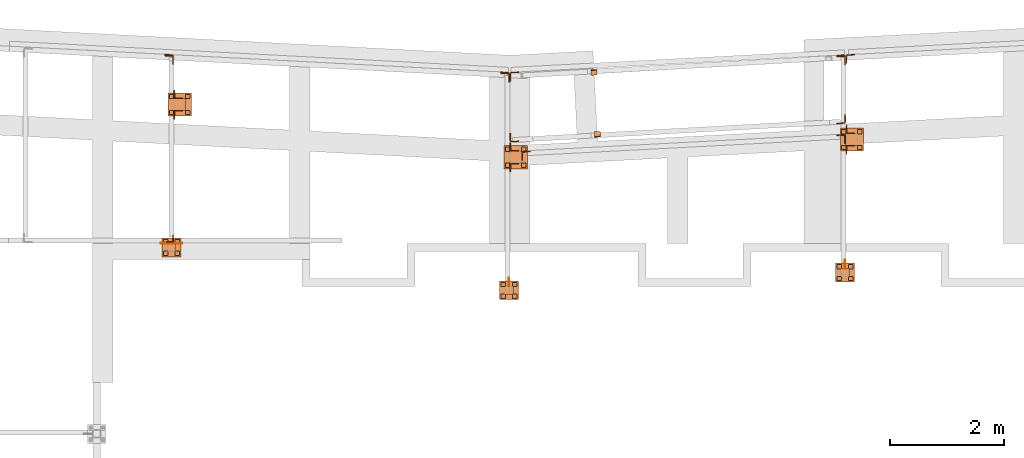
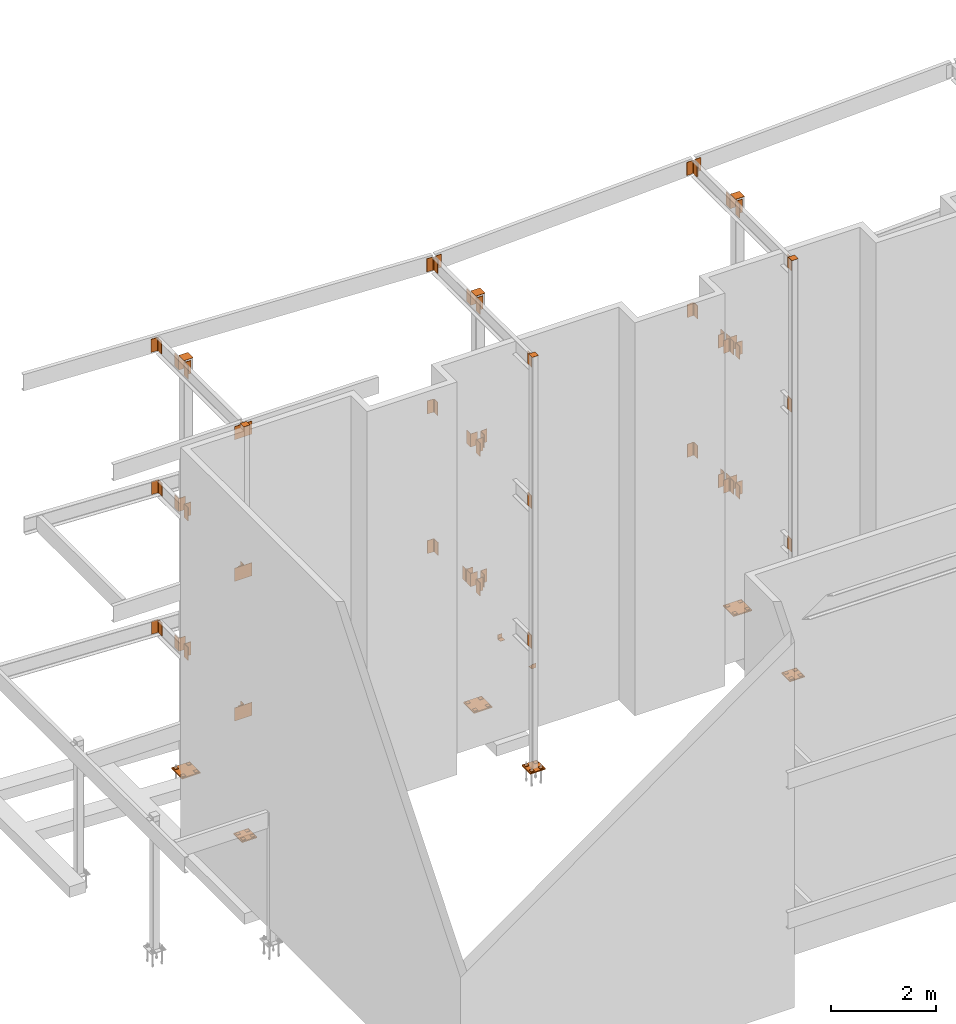
# One storey, part 8 of 89: 86 proxies.
"""IFC4 building model written with IfcOpenShell, lengths in feet."""

from ifc_helpers import new_model, entity, si_unit, converted_unit, derived_unit, direction, frame, origin, origin_2d_with_axis, place, context, subcontext, project, spatial, polyline, rectangle, outline, extrude, source, transform, mapped, material, type_object, type_shapes, element, save


model = new_model("IFC4")

# Units and contexts
model_context = context("Model", 3, precision=0.0001, world=origin(), true_north=direction((6.12303176911189e-17, 1.0)))
body_context = subcontext(model_context, "Body", "Model", "MODEL_VIEW")
ifc_project = project(units=[converted_unit("LENGTHUNIT", "FOOT", entity("IfcRatioMeasure", 0.3048), si_unit("LENGTHUNIT", "METRE"), dimensions=[1, 0, 0, 0, 0, 0, 0]), converted_unit("AREAUNIT", "SQUARE FOOT", entity("IfcRatioMeasure", 0.09290304), si_unit("AREAUNIT", "SQUARE_METRE"), dimensions=[2, 0, 0, 0, 0, 0, 0]), converted_unit("VOLUMEUNIT", "CUBIC FOOT", entity("IfcRatioMeasure", 0.028316846592), si_unit("VOLUMEUNIT", "CUBIC_METRE"), dimensions=[3, 0, 0, 0, 0, 0, 0]), si_unit("PLANEANGLEUNIT", "RADIAN"), si_unit("MASSUNIT", "GRAM", prefix="KILO"), derived_unit("MASSDENSITYUNIT", [(si_unit("MASSUNIT", "GRAM", prefix="KILO"), 1), (si_unit("LENGTHUNIT", "METRE"), -3)]), derived_unit("MOMENTOFINERTIAUNIT", [(si_unit("LENGTHUNIT", "METRE"), 4)]), si_unit("TIMEUNIT", "SECOND"), si_unit("FREQUENCYUNIT", "HERTZ"), si_unit("THERMODYNAMICTEMPERATUREUNIT", "DEGREE_CELSIUS"), derived_unit("THERMALTRANSMITTANCEUNIT", [(si_unit("MASSUNIT", "GRAM", prefix="KILO"), 1), (si_unit("THERMODYNAMICTEMPERATUREUNIT", "KELVIN"), -1), (si_unit("TIMEUNIT", "SECOND"), -3)]), derived_unit("VOLUMETRICFLOWRATEUNIT", [(si_unit("LENGTHUNIT", "METRE"), 3), (si_unit("TIMEUNIT", "SECOND"), -1)]), si_unit("ELECTRICCURRENTUNIT", "AMPERE"), si_unit("ELECTRICVOLTAGEUNIT", "VOLT"), si_unit("POWERUNIT", "WATT"), si_unit("FORCEUNIT", "NEWTON"), si_unit("ILLUMINANCEUNIT", "LUX"), si_unit("LUMINOUSFLUXUNIT", "LUMEN"), si_unit("LUMINOUSINTENSITYUNIT", "CANDELA"), derived_unit("USERDEFINED", [(si_unit("MASSUNIT", "GRAM", prefix="KILO"), -1), (si_unit("LENGTHUNIT", "METRE"), -2), (si_unit("TIMEUNIT", "SECOND"), 3), (si_unit("LUMINOUSFLUXUNIT", "LUMEN"), 1)]), derived_unit("LINEARVELOCITYUNIT", [(si_unit("LENGTHUNIT", "METRE"), 1), (si_unit("TIMEUNIT", "SECOND"), -1)]), si_unit("PRESSUREUNIT", "PASCAL"), derived_unit("USERDEFINED", [(si_unit("LENGTHUNIT", "METRE"), -2), (si_unit("MASSUNIT", "GRAM", prefix="KILO"), 1), (si_unit("TIMEUNIT", "SECOND"), -2)]), derived_unit("LINEARFORCEUNIT", [(si_unit("MASSUNIT", "GRAM", prefix="KILO"), 1), (si_unit("LENGTHUNIT", "METRE"), 1), (si_unit("TIMEUNIT", "SECOND"), -2), (si_unit("LENGTHUNIT", "METRE"), -1)]), derived_unit("PLANARFORCEUNIT", [(si_unit("MASSUNIT", "GRAM", prefix="KILO"), 1), (si_unit("LENGTHUNIT", "METRE"), 1), (si_unit("TIMEUNIT", "SECOND"), -2), (si_unit("LENGTHUNIT", "METRE"), -2)])], contexts=[model_context])

# Site, building, storey
site_placement = place(None, origin())
site = spatial("IfcSite", under=ifc_project, at=site_placement, CompositionType="ELEMENT")
building_placement = place(site_placement, frame((-472.238160486, -49.138065117, 0.0)))
building = spatial("IfcBuilding", under=site, at=building_placement, CompositionType="ELEMENT")
storey_placement = place(building_placement, origin())
storey = spatial("IfcBuildingStorey", under=building, at=storey_placement, Name="Level 1", CompositionType="ELEMENT", Elevation=0.0)

# Proxies
ifc_material_1 = material(Name="Color 7722", Category="Materials")
building_element_proxy_type_1 = type_object("IfcBuildingElementProxyType", Name="MATERIAL 9060:MATERIAL 9060", PredefinedType="NOTDEFINED", material=ifc_material_1)
shared_shape_1 = source(origin(), body_context, "Body", "SweptSolid", [
    extrude(rectangle(XDim=0.25, YDim=0.25, at=origin_2d_with_axis()), frame((0.125, -0.125, 0.0)), (0.0, 0.0, 1.0), 0.03125),
])
type_shapes(building_element_proxy_type_1, [shared_shape_1])
for number, where, z_axis, x_axis, name in (
    (1, (249.583333333333, 1014.56770833333, -0.364583333333333), (0.0, 0.0, -1.0), (0.0, -1.0, 0.0), "PW1"),
    (2, (250.5, 1013.65104166667, -0.364583333333333), (0.0, 0.0, -1.0), (0.0, -1.0, 0.0), "PW1"),
    (3, (249.3125, 1006.78645833333, -0.677083333333333), (0.0, 0.0, -1.0), (0.0, -1.0, 0.0), "PW1"),
    (4, (249.979166666667, 1006.78645833333, -0.677083333333333), (0.0, 0.0, -1.0), (0.0, -1.0, 0.0), "PW1"),
    (5, (249.979166666667, 1006.11979166667, -0.677083333333333), (0.0, 0.0, -1.0), (0.0, -1.0, 0.0), "PW1"),
    (6, (250.5, 1014.56770833333, -0.364583333333333), (0.0, 0.0, -1.0), (0.0, -1.0, 0.0), "PW1"),
    (7, (230.25, 1013.55208333333, -0.364583333333333), (0.0, 0.0, -1.0), (0.0, -1.0, 0.0), "PW1"),
    (8, (231.166666666667, 1013.55208333333, -0.364583333333333), (0.0, 0.0, -1.0), (0.0, -1.0, 0.0), "PW1"),
    (9, (231.166666666667, 1012.63541666667, -0.364583333333333), (0.0, 0.0, -1.0), (0.0, -1.0, 0.0), "PW1"),
    (10, (229.979166666667, 1005.77083333333, -0.34375), (0.0, 0.0, -1.0), (0.0, -1.0, 0.0), "PW1"),
    (11, (230.645833333333, 1005.77083333333, -0.34375), (0.0, 0.0, -1.0), (0.0, -1.0, 0.0), "PW1"),
    (12, (230.645833333333, 1005.10416666667, -0.34375), (0.0, 0.0, -1.0), (0.0, -1.0, 0.0), "PW1"),
    (13, (249.3125, 1006.11979166667, -0.677083333333333), (0.0, 0.0, -1.0), (0.0, -1.0, 0.0), "PW1"),
    (14, (249.583333333333, 1013.65104166667, -0.364583333333333), (0.0, 0.0, -1.0), (0.0, -1.0, 0.0), "PW1"),
    (15, (229.979166666667, 1005.10416666667, -0.34375), (0.0, 0.0, -1.0), (0.0, -1.0, 0.0), "PW1"),
    (16, (230.25, 1012.63541666667, -0.364583333333333), (0.0, 0.0, -1.0), (0.0, -1.0, 0.0), "PW1"),
    (17, (210.567708333333, 1007.5625, -0.260416666666667), (0.0, 0.0, -1.0), (0.0, -1.0, 0.0), "PW1"),
    (18, (210.567708333333, 1008.22916666667, -0.260416666666667), (0.0, 0.0, -1.0), (0.0, -1.0, 0.0), "PW1"),
    (19, (211.234375, 1008.22916666667, -0.260416666666667), (0.0, 0.0, -1.0), (0.0, -1.0, 0.0), "PW1"),
    (20, (211.234375, 1007.5625, -0.260416666666667), (0.0, 0.0, -1.0), (0.0, -1.0, 0.0), "PW1"),
    (21, (211.833333333333, 1015.66666666667, -0.447916666666667), (0.0, 0.0, -1.0), (0.0, -1.0, 0.0), "PW1"),
    (22, (210.916666666667, 1015.66666666667, -0.447916666666667), (0.0, 0.0, -1.0), (0.0, -1.0, 0.0), "PW1"),
    (23, (211.833333333333, 1016.58333333333, -0.447916666666667), (0.0, 0.0, -1.0), (0.0, -1.0, 0.0), "PW1"),
    (24, (210.916666666667, 1016.58333333333, -0.447916666666667), (0.0, 0.0, -1.0), (0.0, -1.0, 0.0), "PW1"),
):
    element("IfcBuildingElementProxy", number, at=place(building_placement, frame(where, z_axis=z_axis, x_axis=x_axis)), inside=storey, type_object=building_element_proxy_type_1, material=ifc_material_1, Name=name, ObjectType="MATERIAL", PredefinedType="NOTDEFINED", context=body_context, shape_type="MappedRepresentation", body=[
        mapped(shared_shape_1, transform((0.0, 0.0, 0.0), scale=1.0)),
    ])
ifc_material_2 = material(Name="Color 7718", Category="Materials")
building_element_proxy_type_2 = type_object("IfcBuildingElementProxyType", Name="MATERIAL 9713:MATERIAL 9713", PredefinedType="NOTDEFINED", material=ifc_material_2)
shared_shape_2 = source(origin(), body_context, "Body", "SweptSolid", [
    extrude(outline(polyline([(-0.0916239487102203, -0.241709384623146), (-0.0603739487102203, -0.241709384623146), (-0.0603739487102203, 0.0291239487101845), (-0.0579951841011973, 0.0410828059715835), (-0.0512210356222993, 0.0512210356223565), (-0.0410828059716293, 0.0579951841011865), (-0.0291239487102203, 0.0603739487102815), (0.241709384623114, 0.0603739487102815), (0.241709384623114, 0.0916239487102095), (-0.0916239487102203, 0.0916239487102095), (-0.0916239487102203, -0.241709384623146)])), frame((0.0, -0.0916239487102203, 0.0916239487102095), z_axis=(1.0, 0.0, 0.0), x_axis=(0.0, -1.0, 0.0)), (0.0, 0.0, 1.0), 0.333333333333366),
])
type_shapes(building_element_proxy_type_2, [shared_shape_2])
for number, where, z_axis, x_axis, name in (
    (25, (235.377131350638, 1014.1123244378, 0.0), (-0.0556972760759885, 0.998447701904168, 0.0), (0.998447701904168, 0.055697276075988, 0.0), "a17"),
    (26, (235.492295262621, 1018.02898524579, 0.0), (0.0556972760759748, -0.998447701904169, 0.0), (-0.998447701904169, -0.0556972760759755, 0.0), "a17"),
):
    element("IfcBuildingElementProxy", number, at=place(building_placement, frame(where, z_axis=z_axis, x_axis=x_axis)), inside=storey, type_object=building_element_proxy_type_2, material=ifc_material_2, Name=name, ObjectType="MATERIAL", PredefinedType="NOTDEFINED", context=body_context, shape_type="MappedRepresentation", body=[
        mapped(shared_shape_2, transform((0.0, 0.0, 0.0), scale=1.0)),
    ])
building_element_proxy_type_3 = type_object("IfcBuildingElementProxyType", Name="MATERIAL 9158:MATERIAL 9158", PredefinedType="NOTDEFINED", material=ifc_material_2)
shared_shape_3 = source(origin(), body_context, "Body", "SweptSolid", [
    extrude(outline(polyline([(0.0111715792294897, -0.0976026118399068), (0.407378579745101, -0.0976026118399068), (0.407378579745101, -0.0611442785065728), (0.0111715792294897, -0.0611442785065728), (-0.00708529606607824, -0.0588217106174638), (-0.0241791222467533, -0.0520019654854818), (-0.0390209419147643, -0.0411194930595618), (-0.0506652611151263, -0.0268675581902408), (-0.0583702817624623, -0.0101540763871088), (-0.0616451576796762, 0.00795622468403817), (-0.0823810299218372, 0.403620237275397), (-0.118789398376419, 0.401712155537369), (-0.0980535261342592, 0.00604814294601114), (-0.0931412122585143, -0.0211173086606718), (-0.0815836812875102, -0.0461875313654078), (-0.0641172024869673, -0.0675654336693708), (-0.0418544729849502, -0.0838891423082878), (-0.0162137337138623, -0.0941187600062608), (0.0111715792294897, -0.0976026118399068)])), frame((0.0, -0.0926214202548993, -0.0976026118399068), z_axis=(1.0, 0.0, 0.0), x_axis=(0.0, -1.0, 0.0)), (0.0, 0.0, 1.0), 1.0),
])
type_shapes(building_element_proxy_type_3, [shared_shape_3])
for number, where, z_axis, x_axis, name in (
    (27, (249.803150643127, 1014.9170636121, 9.47916666666663), (0.0556972760760225, -0.998447701904167, 0.0), (0.0, 0.0, -1.0), "p56"),
    (28, (249.803351183028, 1014.91707479899, 20.1458333333333), (0.0556972760760225, -0.998447701904167, 0.0), (0.0, 0.0, -1.0), "p56"),
    (29, (211.133333333333, 1018.86506263641, 30.9583333333333), (1.0, 0.0, 0.0), (0.0, 0.0, -1.0), "p59"),
    (30, (230.5, 1017.85019473096, 29.9583333333333), (-1.0, 0.0, 0.0), (0.0, 0.0, 1.0), "p59"),
    (31, (230.466666666667, 1017.85019473096, 30.9583333333333), (1.0, 0.0, 0.0), (0.0, 0.0, -1.0), "p59"),
    (32, (249.833333333333, 1018.86257846376, 29.9583333333333), (-1.0, 0.0, 0.0), (0.0, 0.0, 1.0), "p76"),
    (33, (211.133333333333, 1018.80343295489, 20.1458333333333), (1.0, 0.0, 0.0), (0.0, 0.0, -1.0), "p59"),
    (34, (230.466666666667, 1017.79173894847, 20.1458333333333), (1.0, 0.0, 0.0), (0.0, 0.0, -1.0), "p59"),
    (35, (211.133333333333, 1018.80284520582, 9.47916666666667), (1.0, 0.0, 0.0), (0.0, 0.0, -1.0), "p59"),
    (36, (230.466666666667, 1017.79020134977, 9.47916666666667), (1.0, 0.0, 0.0), (0.0, 0.0, -1.0), "p59"),
    (37, (231.166666666667, 1013.296875, 19.1458333333333), (-1.0, 0.0, 0.0), (0.0, 0.0, 1.0), "p61"),
    (38, (231.166666666667, 1013.296875, 8.47916666666667), (-1.0, 0.0, 0.0), (0.0, 0.0, 1.0), "p61"),
):
    element("IfcBuildingElementProxy", number, at=place(building_placement, frame(where, z_axis=z_axis, x_axis=x_axis)), inside=storey, type_object=building_element_proxy_type_3, material=ifc_material_2, Name=name, ObjectType="MATERIAL", PredefinedType="NOTDEFINED", context=body_context, shape_type="MappedRepresentation", body=[
        mapped(shared_shape_3, transform((0.0, 0.0, 0.0), scale=1.0)),
    ])
building_element_proxy_type_4 = type_object("IfcBuildingElementProxyType", Name="MATERIAL 9508:MATERIAL 9508", PredefinedType="NOTDEFINED", material=ifc_material_2)
shared_shape_4 = source(origin(), body_context, "Body", "SweptSolid", [
    extrude(outline(polyline([(0.00933795100327561, -0.100513615372161), (0.394080749800685, -0.100513615372161), (0.394080749800685, -0.0640552820388279), (0.00933795100327567, -0.0640552820388279), (-0.0101481805857443, -0.0614033359186079), (-0.0282169086254994, -0.0536403977150289), (-0.0435539302164183, -0.0413311365164909), (-0.0550436443093494, -0.0253709168252909), (-0.0618502995158724, -0.0069206705551659), (-0.0634787859058903, 0.0126775481038942), (-0.0433429036232124, 0.396893070267087), (-0.0797512720777954, 0.398801152005115), (-0.0998871543604734, 0.0145856298419221), (-0.0974444247755213, -0.0148116981466309), (-0.0872344419656624, -0.0424870675518559), (-0.0699998708261134, -0.0664273970886559), (-0.0469943384400384, -0.0848912888864439), (-0.0198912463803294, -0.0965356961918699), (0.00933795100327561, -0.100513615372161)])), frame((0.0, 0.394080749800685, 0.398801152005115), z_axis=(1.0, 0.0, 0.0), x_axis=(0.0, -1.0, 0.0)), (0.0, 0.0, 1.0), 1.0),
])
type_shapes(building_element_proxy_type_4, [shared_shape_4])
for number, where, z_axis, x_axis, name in (
    (39, (230.973096906464, 1014.36843247792, 8.47916666666667), (0.0556972760760702, -0.998447701904164, 0.0), (0.0, 0.0, 1.0), "p60"),
    (40, (249.300685232623, 1018.36257846376, 30.9583333333333), (1.0, 0.0, 0.0), (0.0, 0.0, -1.0), "p62"),
    (41, (249.32681734844, 1013.7502002313, 19.1458333333333), (-0.0523359562429422, 0.998629534754574, 0.0), (0.0, 0.0, 1.0), "p60"),
    (42, (249.300760986889, 1018.30449523805, 20.1458333333333), (1.0, 0.0, 0.0), (0.0, 0.0, -1.0), "p75"),
    (43, (249.32681734844, 1013.7502002313, 8.47916666666667), (-0.0523359562429422, 0.998629534754574, 0.0), (0.0, 0.0, 1.0), "p60"),
    (44, (249.300685232623, 1018.30215561513, 9.47916666666667), (1.0, 0.0, 0.0), (0.0, 0.0, -1.0), "p62"),
):
    element("IfcBuildingElementProxy", number, at=place(building_placement, frame(where, z_axis=z_axis, x_axis=x_axis)), inside=storey, type_object=building_element_proxy_type_4, material=ifc_material_2, Name=name, ObjectType="MATERIAL", PredefinedType="NOTDEFINED", context=body_context, shape_type="MappedRepresentation", body=[
        mapped(shared_shape_4, transform((0.0, 0.0, 0.0), scale=1.0)),
    ])
building_element_proxy_type_5 = type_object("IfcBuildingElementProxyType", Name="CONNECTION MATERIAL 9087:CONNECTION MATERIAL 9087", PredefinedType="NOTDEFINED", material=ifc_material_2)
shared_shape_5 = source(origin(), body_context, "Body", "SweptSolid", [
    extrude(rectangle(XDim=0.458333333333333, YDim=0.458333333333333, at=origin_2d_with_axis()), frame((0.0, 0.0, -0.0208333333333333)), (0.0, 0.0, 1.0), 0.0208333333333333),
])
type_shapes(building_element_proxy_type_5, [shared_shape_5])
for number, where, z_axis, x_axis, name in (
    (45, (249.770833333333, 1006.328125, 31.0625), (0.0, 0.0, -1.0), (1.0, 0.0, 0.0), "cp2"),
    (46, (230.4375, 1005.3125, 31.0625), (0.0, 0.0, -1.0), (1.0, 0.0, 0.0), "cp2"),
    (47, (211.026041666667, 1007.77083333333, 31.0625), (0.0, 0.0, -1.0), (1.0, 0.0, 0.0), "cp2"),
):
    element("IfcBuildingElementProxy", number, at=place(building_placement, frame(where, z_axis=z_axis, x_axis=x_axis)), inside=storey, type_object=building_element_proxy_type_5, material=ifc_material_2, Name=name, ObjectType="CONNECTION MATERIAL", PredefinedType="NOTDEFINED", context=body_context, shape_type="MappedRepresentation", body=[
        mapped(shared_shape_5, transform((0.0, 0.0, 0.0), scale=1.0)),
    ])
building_element_proxy_type_6 = type_object("IfcBuildingElementProxyType", Name="CONNECTION MATERIAL 9070:CONNECTION MATERIAL 9070", PredefinedType="NOTDEFINED", material=ifc_material_2)
shared_shape_6 = source(origin(), body_context, "Body", "SweptSolid", [
    extrude(rectangle(XDim=1.08333333333333, YDim=1.08333333333333, at=origin_2d_with_axis()), frame((0.0, 0.0, -0.0833333333333333)), (0.0, 0.0, 1.0), 0.0833333333333333),
])
type_shapes(building_element_proxy_type_6, [shared_shape_6])
for number, where, name in (
    (48, (249.770833333333, 1006.328125, -0.708333333333333), "bp1"),
    (49, (230.4375, 1005.3125, -0.375), "bp1"),
    (50, (211.026041666667, 1007.77083333333, -0.291666666666667), "bp1"),
):
    element("IfcBuildingElementProxy", number, at=place(building_placement, frame(where)), inside=storey, type_object=building_element_proxy_type_6, material=ifc_material_2, Name=name, ObjectType="CONNECTION MATERIAL", PredefinedType="NOTDEFINED", context=body_context, shape_type="MappedRepresentation", body=[
        mapped(shared_shape_6, transform((0.0, 0.0, 0.0), scale=1.0)),
    ])
ifc_material_3 = material(Name="Color", Category="Materials")
building_element_proxy_type_7 = type_object("IfcBuildingElementProxyType", Name="MATERIAL 9551:MATERIAL 9551", PredefinedType="NOTDEFINED", material=ifc_material_3)
shared_shape_7 = source(origin(), body_context, "Body", "SweptSolid", [
    extrude(outline(polyline([(-0.110359709391404, -0.110359709391408), (0.306306957275262, -0.110359709391408), (0.306306957275262, -0.0791097093914077), (-0.0374430427247379, -0.0791097093914077), (-0.0533881857399629, -0.0759380232460297), (-0.0669058252741819, -0.0669058252741097), (-0.0759380232460259, -0.0533881857400047), (-0.0791097093914039, -0.0374430427247417), (-0.0791097093914039, 0.306306957275258), (-0.110359709391404, 0.306306957275258), (-0.110359709391404, -0.110359709391408)])), frame((0.0, -0.110359709391404, -0.110359709391408), z_axis=(1.0, 0.0, 0.0), x_axis=(0.0, -1.0, 0.0)), (0.0, 0.0, 1.0), 1.0),
])
type_shapes(building_element_proxy_type_7, [shared_shape_7])
for number, where, z_axis, x_axis, name in (
    (51, (211.133333333333, 1008.075, 30.9583333333333), (0.0, -1.0, 0.0), (0.0, 0.0, -1.0), "a12"),
    (52, (211.133333333333, 1008.075, 20.1458333333333), (0.0, -1.0, 0.0), (0.0, 0.0, -1.0), "a12"),
    (53, (211.133333333333, 1008.075, 9.47916666666667), (0.0, -1.0, 0.0), (0.0, 0.0, -1.0), "a12"),
):
    element("IfcBuildingElementProxy", number, at=place(building_placement, frame(where, z_axis=z_axis, x_axis=x_axis)), inside=storey, type_object=building_element_proxy_type_7, material=ifc_material_3, Name=name, ObjectType="MATERIAL", PredefinedType="NOTDEFINED", context=body_context, shape_type="MappedRepresentation", body=[
        mapped(shared_shape_7, transform((0.0, 0.0, 0.0), scale=1.0)),
    ])
building_element_proxy_type_8 = type_object("IfcBuildingElementProxyType", Name="MATERIAL:MATERIAL", PredefinedType="NOTDEFINED", material=ifc_material_2)
shared_shape_8 = source(origin(), body_context, "Body", "SweptSolid", [
    extrude(outline(polyline([(-0.130151376058071, -0.130151376058075), (0.369848623941929, -0.130151376058075), (0.369848623941929, -0.0936930427247416), (-0.0520263760580709, -0.0936930427247416), (-0.0679715190732959, -0.0905213565793626), (-0.0814891586075149, -0.0814891586074436), (-0.0905213565793589, -0.0679715190733376), (-0.0936930427247379, -0.0520263760580746), (-0.0936930427247379, 0.369848623941925), (-0.130151376058071, 0.369848623941925), (-0.130151376058071, -0.130151376058075)])), frame((0.0, -0.130151376058071, -0.130151376058075), z_axis=(1.0, 0.0, 0.0), x_axis=(0.0, -1.0, 0.0)), (0.0, 0.0, 1.0), 1.0),
])
type_shapes(building_element_proxy_type_8, [shared_shape_8])
for number, where, z_axis, x_axis, name in (
    (54, (230.5, 1013.30208333333, 30.9583333333333), (-1.0, 0.0, 0.0), (0.0, 0.0, -1.0), "a15"),
    (55, (230.5, 1012.63541666667, 30.9583333333333), (0.0, 1.0, 0.0), (0.0, 0.0, -1.0), "a15"),
    (56, (230.5, 1013.30208333333, 20.1458333333333), (-1.0, 0.0, 0.0), (0.0, 0.0, -1.0), "a15"),
    (57, (230.5, 1012.63541666667, 20.1458333333333), (0.0, 1.0, 0.0), (0.0, 0.0, -1.0), "a15"),
    (58, (230.5, 1013.30208333333, 9.47916666666667), (-1.0, 0.0, 0.0), (0.0, 0.0, -1.0), "a15"),
    (59, (230.5, 1012.63541666667, 9.47916666666667), (0.0, 1.0, 0.0), (0.0, 0.0, -1.0), "a15"),
    (60, (249.833333333333, 1014.31770833333, 30.9583333333333), (-1.0, 0.0, 0.0), (0.0, 0.0, -1.0), "a15"),
    (61, (249.833333333333, 1013.65104166667, 30.9583333333333), (0.0, 1.0, 0.0), (0.0, 0.0, -1.0), "a15"),
    (62, (249.833333333333, 1014.31770833333, 20.1458333333333), (-1.0, 0.0, 0.0), (0.0, 0.0, -1.0), "a15"),
    (63, (249.833333333333, 1013.65104166667, 20.1458333333333), (0.0, 1.0, 0.0), (0.0, 0.0, -1.0), "a15"),
    (64, (249.833333333333, 1014.31770833333, 9.47916666666667), (-1.0, 0.0, 0.0), (0.0, 0.0, -1.0), "a15"),
    (65, (249.833333333333, 1013.65104166667, 9.47916666666667), (0.0, 1.0, 0.0), (0.0, 0.0, -1.0), "a15"),
    (66, (211.166666666667, 1016.33333333333, 30.9583333333333), (-1.0, 0.0, 0.0), (0.0, 0.0, -1.0), "a15"),
    (67, (211.166666666667, 1015.66666666667, 30.9583333333333), (0.0, 1.0, 0.0), (0.0, 0.0, -1.0), "a15"),
    (68, (211.166666666667, 1016.33333333333, 20.1458333333333), (-1.0, 0.0, 0.0), (0.0, 0.0, -1.0), "a15"),
    (69, (211.166666666667, 1015.66666666667, 20.1458333333333), (0.0, 1.0, 0.0), (0.0, 0.0, -1.0), "a15"),
    (70, (211.166666666667, 1016.33333333333, 9.47916666666667), (-1.0, 0.0, 0.0), (0.0, 0.0, -1.0), "a15"),
    (71, (211.166666666667, 1015.66666666667, 9.47916666666667), (0.0, 1.0, 0.0), (0.0, 0.0, -1.0), "a15"),
):
    element("IfcBuildingElementProxy", number, at=place(building_placement, frame(where, z_axis=z_axis, x_axis=x_axis)), inside=storey, type_object=building_element_proxy_type_8, material=ifc_material_2, Name=name, ObjectType="MATERIAL", PredefinedType="NOTDEFINED", context=body_context, shape_type="MappedRepresentation", body=[
        mapped(shared_shape_8, transform((0.0, 0.0, 0.0), scale=1.0)),
    ])
building_element_proxy_type_9 = type_object("IfcBuildingElementProxyType", Name="CONNECTION MATERIAL 9054:CONNECTION MATERIAL 9054", PredefinedType="NOTDEFINED", material=ifc_material_2)
shared_shape_9 = source(origin(), body_context, "Body", "SweptSolid", [
    extrude(rectangle(XDim=0.666666666666667, YDim=0.666666666666667, at=origin_2d_with_axis()), frame((0.0, 0.0, -0.0208333333333333)), (0.0, 0.0, 1.0), 0.0208333333333333),
])
type_shapes(building_element_proxy_type_9, [shared_shape_9])
for number, where, z_axis, x_axis, name in (
    (72, (230.833333333333, 1012.96875, 31.0625), (0.0, 0.0, -1.0), (1.0, 0.0, 0.0), "cp1"),
    (73, (250.166666666667, 1013.984375, 31.0625), (0.0, 0.0, -1.0), (1.0, 0.0, 0.0), "cp1"),
    (74, (211.5, 1016.0, 31.0625), (0.0, 0.0, -1.0), (1.0, 0.0, 0.0), "cp1"),
):
    element("IfcBuildingElementProxy", number, at=place(building_placement, frame(where, z_axis=z_axis, x_axis=x_axis)), inside=storey, type_object=building_element_proxy_type_9, material=ifc_material_2, Name=name, ObjectType="CONNECTION MATERIAL", PredefinedType="NOTDEFINED", context=body_context, shape_type="MappedRepresentation", body=[
        mapped(shared_shape_9, transform((0.0, 0.0, 0.0), scale=1.0)),
    ])
building_element_proxy_type_10 = type_object("IfcBuildingElementProxyType", Name="CONNECTION MATERIAL:CONNECTION MATERIAL", PredefinedType="NOTDEFINED", material=ifc_material_2)
shared_shape_10 = source(origin(), body_context, "Body", "SweptSolid", [
    extrude(rectangle(XDim=1.33333333333333, YDim=1.33333333333333, at=origin_2d_with_axis()), frame((0.0, 0.0, -0.0833333333333333)), (0.0, 0.0, 1.0), 0.0833333333333333),
])
type_shapes(building_element_proxy_type_10, [shared_shape_10])
for number, where, name in (
    (75, (230.833333333333, 1012.96875, -0.395833333333333), "bp2"),
    (76, (250.166666666667, 1013.984375, -0.395833333333333), "bp2"),
    (77, (211.5, 1016.0, -0.479166666666667), "bp2"),
):
    element("IfcBuildingElementProxy", number, at=place(building_placement, frame(where)), inside=storey, type_object=building_element_proxy_type_10, material=ifc_material_2, Name=name, ObjectType="CONNECTION MATERIAL", PredefinedType="NOTDEFINED", context=body_context, shape_type="MappedRepresentation", body=[
        mapped(shared_shape_10, transform((0.0, 0.0, 0.0), scale=1.0)),
    ])
building_element_proxy_type_11 = type_object("IfcBuildingElementProxyType", Name="MATERIAL 9080:MATERIAL 9080", PredefinedType="NOTDEFINED", material=ifc_material_3)
shared_shape_11 = source(origin(), body_context, "Body", "SweptSolid", [
    extrude(rectangle(XDim=1.25, YDim=1.0, at=origin_2d_with_axis()), frame((0.625, -0.5, 0.0)), (0.0, 0.0, 1.0), 0.0364583333333333),
])
type_shapes(building_element_proxy_type_11, [shared_shape_11])
for number, where, z_axis, x_axis, name in (
    (78, (210.401041666667, 1008.03645833333, 30.9583333333333), (0.0, -1.0, 0.0), (1.0, 0.0, 0.0), "p23"),
    (79, (210.401041666667, 1008.03645833333, 20.1458333333333), (0.0, -1.0, 0.0), (1.0, 0.0, 0.0), "p23"),
    (80, (210.401041666667, 1008.03645833333, 9.47916666666667), (0.0, -1.0, 0.0), (1.0, 0.0, 0.0), "p23"),
):
    element("IfcBuildingElementProxy", number, at=place(building_placement, frame(where, z_axis=z_axis, x_axis=x_axis)), inside=storey, type_object=building_element_proxy_type_11, material=ifc_material_3, Name=name, ObjectType="MATERIAL", PredefinedType="NOTDEFINED", context=body_context, shape_type="MappedRepresentation", body=[
        mapped(shared_shape_11, transform((0.0, 0.0, 0.0), scale=1.0)),
    ])
building_element_proxy_type_12 = type_object("IfcBuildingElementProxyType", Name="MATERIAL 9089:MATERIAL 9089", PredefinedType="NOTDEFINED", material=ifc_material_2)
shared_shape_12 = source(origin(), body_context, "Body", "SweptSolid", [
    extrude(rectangle(XDim=1.0, YDim=0.5, at=origin_2d_with_axis()), frame((0.5, -0.25, 0.0)), (0.0, 0.0, 1.0), 0.0364583333333333),
])
type_shapes(building_element_proxy_type_12, [shared_shape_12])
for number, where, z_axis, x_axis, name in (
    (81, (249.8, 1006.55729166667, 30.9583333333333), (-1.0, 0.0, 0.0), (0.0, 0.0, -1.0), "p21"),
    (82, (249.80007576841, 1006.55729226585, 20.1458333333333), (-1.0, 0.0, 0.0), (0.0, 0.0, -1.0), "p21"),
    (83, (249.799479166667, 1006.55729226585, 9.47916666666667), (-1.0, 0.0, 0.0), (0.0, 0.0, -1.0), "p21"),
    (84, (230.466666666667, 1005.54166666667, 30.9583333333333), (-1.0, 0.0, 0.0), (0.0, 0.0, -1.0), "p21"),
    (85, (230.466666666667, 1005.54166666667, 20.1458333333333), (-1.0, 0.0, 0.0), (0.0, 0.0, -1.0), "p21"),
    (86, (230.466666666667, 1005.54166666667, 9.47916666666667), (-1.0, 0.0, 0.0), (0.0, 0.0, -1.0), "p21"),
):
    element("IfcBuildingElementProxy", number, at=place(building_placement, frame(where, z_axis=z_axis, x_axis=x_axis)), inside=storey, type_object=building_element_proxy_type_12, material=ifc_material_2, Name=name, ObjectType="MATERIAL", PredefinedType="NOTDEFINED", context=body_context, shape_type="MappedRepresentation", body=[
        mapped(shared_shape_12, transform((0.0, 0.0, 0.0), scale=1.0)),
    ])

save(model, "model.ifc")
